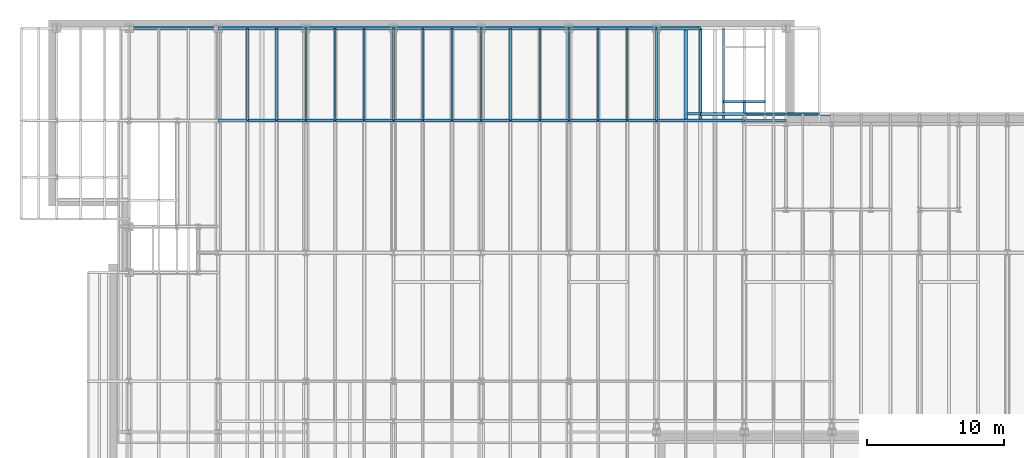
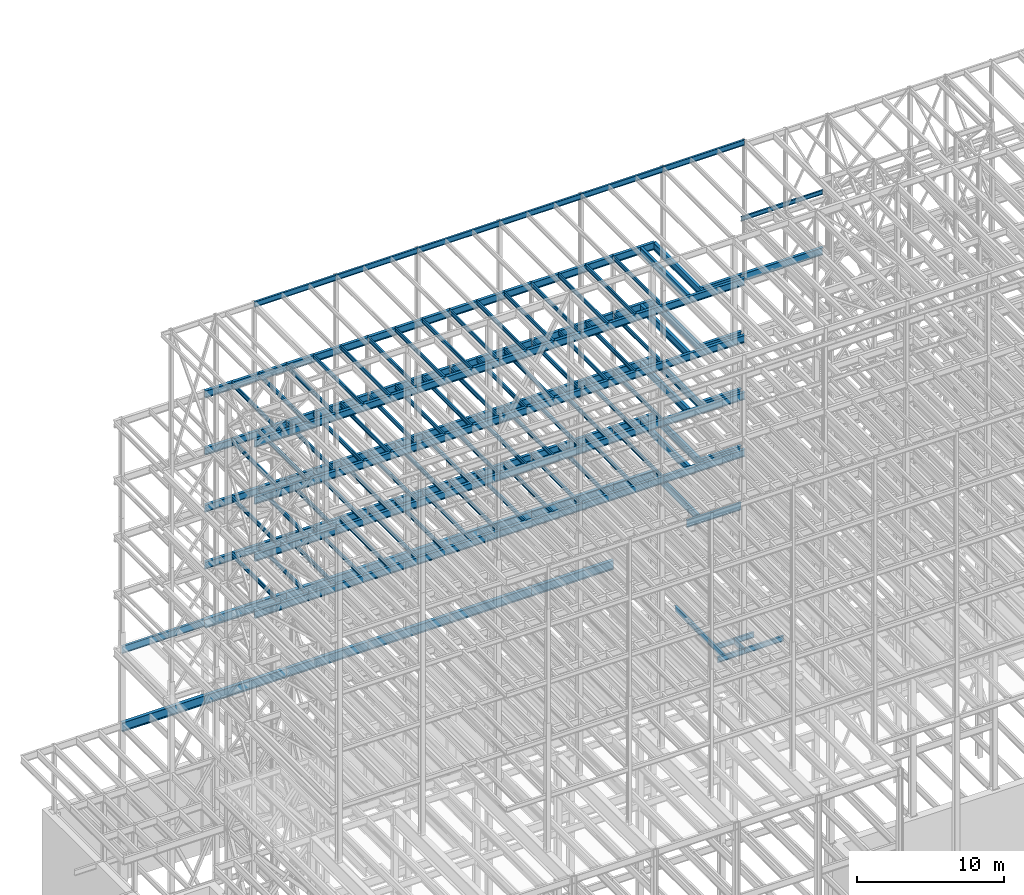
# One storey, part 137 of 150: 148 beams.
"""IFC2X3 building model written with IfcOpenShell, lengths in millimetres."""

from ifc_helpers import new_model, si_unit, frame, origin_with_axes, origin_2d_with_axis, place, context, subcontext, project, spatial, i_section, extrude, material, type_object, element, save


model = new_model("IFC2X3")

# Units and contexts
model_context = context("Model", 3, precision=1e-05, world=origin_with_axes())
body_context = subcontext(model_context, "Body", "Model", "MODEL_VIEW")
ifc_project = project(units=[si_unit("LENGTHUNIT", "METRE", prefix="MILLI"), si_unit("AREAUNIT", "SQUARE_METRE"), si_unit("VOLUMEUNIT", "CUBIC_METRE"), si_unit("MASSUNIT", "GRAM", prefix="KILO"), si_unit("TIMEUNIT", "SECOND"), si_unit("PLANEANGLEUNIT", "RADIAN"), si_unit("SOLIDANGLEUNIT", "STERADIAN"), si_unit("THERMODYNAMICTEMPERATUREUNIT", "DEGREE_CELSIUS"), si_unit("LUMINOUSINTENSITYUNIT", "LUMEN")], contexts=[model_context])

# Site, building, storey
site_placement = place(None, origin_with_axes())
site = spatial("IfcSite", under=ifc_project, at=site_placement, CompositionType="ELEMENT")
building_placement = place(site_placement, origin_with_axes())
building = spatial("IfcBuilding", under=site, at=building_placement, Name="Undefined", CompositionType="ELEMENT")
storey_placement = place(building_placement, origin_with_axes())
storey = spatial("IfcBuildingStorey", under=building, at=storey_placement, Name="Undefined", CompositionType="ELEMENT", Elevation=0.0)

# Beams
ifc_material = material(Name="STEEL/A992")
beam_type_1 = type_object("IfcBeamType", Name="W18X35", PredefinedType="NOTDEFINED")
for number, where, z_axis, x_axis, name in (
    (1, (43789.6, 32131.0, 65687.575), (0.0, 0.0, 1.0), (1.0, 0.0, 0.0), "BEAM"),
    (2, (37388.8, 32131.0, 65687.575), (0.0, 0.0, 1.0), (1.0, 0.0, 0.0), "BEAM"),
):
    element("IfcBeam", number, at=place(storey_placement, frame(where, z_axis=z_axis, x_axis=x_axis)), inside=storey, type_object=beam_type_1, material=ifc_material, Name=name, ObjectType="W18X35", context=body_context, shape_type="SweptSolid", body=[
        extrude(i_section(OverallWidth=152.4, OverallDepth=450.85, WebThickness=7.9375, FlangeThickness=10.795, FilletRadius=17.78, at=origin_2d_with_axis()), frame((6400.80000000001, 0.0, 0.0), z_axis=(-1.0, 0.0, 0.0), x_axis=(0.0, -1.0, 0.0)), (0.0, 0.0, 1.0), 6400.8),
    ])
beam_1_placement = place(storey_placement, frame((30988.0, 32131.0, 65687.575), z_axis=(0.0, 0.0, 1.0), x_axis=(1.0, 0.0, 0.0)))
element("IfcBeam", 3, at=beam_1_placement, inside=storey, type_object=beam_type_1, material=ifc_material, Name="BEAM", ObjectType="W18X35", context=body_context, shape_type="SweptSolid", body=[
    extrude(i_section(OverallWidth=152.4, OverallDepth=450.85, WebThickness=7.9375, FlangeThickness=10.795, FilletRadius=17.78, at=origin_2d_with_axis()), frame((6400.80000000001, 0.0, 0.0), z_axis=(-1.0, 0.0, 0.0), x_axis=(0.0, -1.0, 0.0)), (0.0, 0.0, 1.0), 6400.80000000001),
])
for number, where, z_axis, x_axis, name in (
    (4, (24587.2, 32131.0, 65687.575), (0.0, 0.0, 1.0), (1.0, 0.0, 0.0), "BEAM"),
    (5, (18186.4, 32131.0, 65687.575), (0.0, 0.0, 1.0), (1.0, 0.0, 0.0), "BEAM"),
    (6, (11785.6, 32131.0, 65687.575), (0.0, 0.0, 1.0), (1.0, 0.0, 0.0), "BEAM"),
):
    element("IfcBeam", number, at=place(storey_placement, frame(where, z_axis=z_axis, x_axis=x_axis)), inside=storey, type_object=beam_type_1, material=ifc_material, Name=name, ObjectType="W18X35", context=body_context, shape_type="SweptSolid", body=[
        extrude(i_section(OverallWidth=152.4, OverallDepth=450.85, WebThickness=7.9375, FlangeThickness=10.795, FilletRadius=17.78, at=origin_2d_with_axis()), frame((6400.80000000001, 0.0, 0.0), z_axis=(-1.0, 0.0, 0.0), x_axis=(0.0, -1.0, 0.0)), (0.0, 0.0, 1.0), 6400.8),
    ])
beam_2_placement = place(storey_placement, frame((50190.4, 32131.0, 23548.975), z_axis=(0.0, 0.0, 1.0), x_axis=(0.0, 1.0, 0.0)))
element("IfcBeam", 7, at=beam_2_placement, inside=storey, type_object=beam_type_1, material=ifc_material, Name="BEAM", ObjectType="W18X35", context=body_context, shape_type="SweptSolid", body=[
    extrude(i_section(OverallWidth=152.4, OverallDepth=450.85, WebThickness=7.9375, FlangeThickness=10.795, FilletRadius=17.78, at=origin_2d_with_axis()), frame((1371.6, 0.0, 0.0), z_axis=(-1.0, 0.0, 0.0), x_axis=(0.0, -1.0, 0.0)), (0.0, 0.0, 1.0), 1371.6),
])
beam_3_placement = place(storey_placement, frame((48666.4, 33502.6, 23548.975), z_axis=(0.0, 0.0, 1.0), x_axis=(1.0, 0.0, 0.0)))
element("IfcBeam", 8, at=beam_3_placement, inside=storey, type_object=beam_type_1, material=ifc_material, Name="BEAM", ObjectType="W18X35", context=body_context, shape_type="SweptSolid", body=[
    extrude(i_section(OverallWidth=152.4, OverallDepth=450.85, WebThickness=7.9375, FlangeThickness=10.795, FilletRadius=17.78, at=origin_2d_with_axis()), frame((3048.0, 0.0, 0.0), z_axis=(-1.0, 0.0, 0.0), x_axis=(0.0, -1.0, 0.0)), (0.0, 0.0, 1.0), 3048.0),
])
beam_4_placement = place(storey_placement, frame((48666.4, 32131.0, 23548.975), z_axis=(0.0, 0.0, 1.0), x_axis=(0.0, 1.0, 0.0)))
element("IfcBeam", 9, at=beam_4_placement, inside=storey, type_object=beam_type_1, material=ifc_material, Name="BEAM", ObjectType="W18X35", context=body_context, shape_type="SweptSolid", body=[
    extrude(i_section(OverallWidth=152.4, OverallDepth=450.85, WebThickness=7.9375, FlangeThickness=10.795, FilletRadius=17.78, at=origin_2d_with_axis()), frame((6731.0, 0.0, 0.0), z_axis=(-1.0, 0.0, 0.0), x_axis=(0.0, -1.0, 0.0)), (0.0, 0.0, 1.0), 6731.0),
])
beam_5_placement = place(storey_placement, frame((48056.8, 32131.0, 23548.975), z_axis=(0.0, 0.0, 1.0), x_axis=(1.0, 0.0, 0.0)))
element("IfcBeam", 10, at=beam_5_placement, inside=storey, type_object=beam_type_1, material=ifc_material, Name="BEAM", ObjectType="W18X35", context=body_context, shape_type="SweptSolid", body=[
    extrude(i_section(OverallWidth=152.4, OverallDepth=450.85, WebThickness=7.9375, FlangeThickness=10.795, FilletRadius=17.78, at=origin_2d_with_axis()), frame((2133.6, 0.0, 0.0), z_axis=(-1.0, 0.0, 0.0), x_axis=(0.0, -1.0, 0.0)), (0.0, 0.0, 1.0), 2133.60000000001),
])
beam_6_placement = place(storey_placement, frame((50190.4, 32131.0, 23548.975), z_axis=(0.0, 0.0, 1.0), x_axis=(1.0, 0.0, 0.0)))
element("IfcBeam", 11, at=beam_6_placement, inside=storey, type_object=beam_type_1, material=ifc_material, Name="BEAM", ObjectType="W18X35", context=body_context, shape_type="SweptSolid", body=[
    extrude(i_section(OverallWidth=152.4, OverallDepth=450.85, WebThickness=7.9375, FlangeThickness=10.795, FilletRadius=17.78, at=origin_2d_with_axis()), frame((3048.0, 0.0, 0.0), z_axis=(-1.0, 0.0, 0.0), x_axis=(0.0, -1.0, 0.0)), (0.0, 0.0, 1.0), 3048.0),
])
beam_type_2 = type_object("IfcBeamType", Name="W24X68", PredefinedType="NOTDEFINED")
for number, where, z_axis, x_axis, name in (
    (12, (37388.8, 32131.0, 54181.375), (0.0, 0.0, 1.0), (1.0, 0.0, 0.0), "BEAM"),
    (13, (30988.0, 32131.0, 54181.375), (0.0, 0.0, 1.0), (1.0, 0.0, 0.0), "BEAM"),
    (14, (24587.2, 32131.0, 54181.375), (0.0, 0.0, 1.0), (1.0, 0.0, 0.0), "BEAM"),
    (15, (18186.4, 32131.0, 54181.375), (0.0, 0.0, 1.0), (1.0, 0.0, 0.0), "BEAM"),
    (16, (11785.6, 32131.0, 54181.375), (0.0, 0.0, 1.0), (1.0, 0.0, 0.0), "BEAM"),
    (17, (37388.8, 38862.0, 54181.375), (0.0, 0.0, 1.0), (1.0, 0.0, 0.0), "BEAM"),
    (18, (30988.0, 38862.0, 54181.375), (0.0, 0.0, 1.0), (1.0, 0.0, 0.0), "BEAM"),
    (19, (24587.2, 38862.0, 54181.375), (0.0, 0.0, 1.0), (1.0, 0.0, 0.0), "BEAM"),
    (20, (18186.4, 38862.0, 54181.375), (0.0, 0.0, 1.0), (1.0, 0.0, 0.0), "BEAM"),
    (21, (11785.6, 38862.0, 54181.375), (0.0, 0.0, 1.0), (1.0, 0.0, 0.0), "BEAM"),
):
    element("IfcBeam", number, at=place(storey_placement, frame(where, z_axis=z_axis, x_axis=x_axis)), inside=storey, type_object=beam_type_2, material=ifc_material, Name=name, ObjectType="W24X68", context=body_context, shape_type="SweptSolid", body=[
        extrude(i_section(OverallWidth=227.838, OverallDepth=603.25, WebThickness=11.1125, FlangeThickness=14.859, FilletRadius=23.2409, at=origin_2d_with_axis()), frame((6400.80000000001, 0.0, 0.0), z_axis=(-1.0, 0.0, 0.0), x_axis=(0.0, -1.0, 0.0)), (0.0, 0.0, 1.0), 6400.8),
    ])
beam_7_placement = place(storey_placement, frame((45923.2, 32131.0, 54181.375), z_axis=(0.0, 0.0, 1.0), x_axis=(0.0, 1.0, 0.0)))
element("IfcBeam", 22, at=beam_7_placement, inside=storey, type_object=beam_type_2, material=ifc_material, Name="BEAM", ObjectType="W24X68", context=body_context, shape_type="SweptSolid", body=[
    extrude(i_section(OverallWidth=227.838, OverallDepth=603.25, WebThickness=11.1125, FlangeThickness=14.859, FilletRadius=23.2409, at=origin_2d_with_axis()), frame((6731.0, 0.0, 0.0), z_axis=(-1.0, 0.0, 0.0), x_axis=(0.0, -1.0, 0.0)), (0.0, 0.0, 1.0), 6731.0),
])
beam_8_placement = place(storey_placement, frame((43789.6, 32131.0, 54181.375), z_axis=(0.0, 0.0, 1.0), x_axis=(1.0, 0.0, 0.0)))
element("IfcBeam", 23, at=beam_8_placement, inside=storey, type_object=beam_type_2, material=ifc_material, Name="BEAM", ObjectType="W24X68", context=body_context, shape_type="SweptSolid", body=[
    extrude(i_section(OverallWidth=227.838, OverallDepth=603.25, WebThickness=11.1125, FlangeThickness=14.859, FilletRadius=23.2409, at=origin_2d_with_axis()), frame((6400.79935992001, 0.0, 0.0), z_axis=(-1.0, 0.0, 0.0), x_axis=(0.0, -1.0, 0.0)), (0.0, 0.0, 1.0), 6400.79935992001),
])
beam_9_placement = place(storey_placement, frame((43789.6, 38862.0, 54181.375), z_axis=(0.0, 0.0, 1.0), x_axis=(1.0, 0.0, 0.0)))
element("IfcBeam", 24, at=beam_9_placement, inside=storey, type_object=beam_type_2, material=ifc_material, Name="BEAM", ObjectType="W24X68", context=body_context, shape_type="SweptSolid", body=[
    extrude(i_section(OverallWidth=227.838, OverallDepth=603.25, WebThickness=11.1125, FlangeThickness=14.859, FilletRadius=23.2409, at=origin_2d_with_axis()), frame((3200.4, 0.0, 0.0), z_axis=(-1.0, 0.0, 0.0), x_axis=(0.0, -1.0, 0.0)), (0.0, 0.0, 1.0), 3200.4),
])
beam_10_placement = place(storey_placement, frame((46990.0, 32131.0, 54181.375), z_axis=(0.0, 0.0, 1.0), x_axis=(0.0, 1.0, 0.0)))
element("IfcBeam", 25, at=beam_10_placement, inside=storey, type_object=beam_type_2, material=ifc_material, Name="BEAM", ObjectType="W24X68", context=body_context, shape_type="SweptSolid", body=[
    extrude(i_section(OverallWidth=227.838, OverallDepth=603.25, WebThickness=11.1125, FlangeThickness=14.859, FilletRadius=23.2409, at=origin_2d_with_axis()), frame((6731.0, 0.0, 0.0), z_axis=(-1.0, 0.0, 0.0), x_axis=(0.0, -1.0, 0.0)), (0.0, 0.0, 1.0), 6731.0),
])
beam_11_placement = place(storey_placement, frame((46990.0, 32613.6, 54181.375), z_axis=(0.0, 0.0, 1.0), x_axis=(1.0, 0.0, 0.0)))
element("IfcBeam", 26, at=beam_11_placement, inside=storey, type_object=beam_type_2, material=ifc_material, Name="BEAM", ObjectType="W24X68", context=body_context, shape_type="SweptSolid", body=[
    extrude(i_section(OverallWidth=227.838, OverallDepth=603.25, WebThickness=11.1125, FlangeThickness=14.859, FilletRadius=23.2409, at=origin_2d_with_axis()), frame((3200.4, 0.0, 0.0), z_axis=(-1.0, 0.0, 0.0), x_axis=(0.0, -1.0, 0.0)), (0.0, 0.0, 1.0), 3200.4),
])
for number, where, z_axis, x_axis, name in (
    (27, (50190.4, 32613.6, 54181.375), (0.0, 0.0, 1.0), (1.0, 0.0, 0.0), "BEAM"),
    (28, (37388.8, 32131.0, 49456.975), (0.0, 0.0, 1.0), (1.0, 0.0, 0.0), "BEAM"),
    (29, (30988.0, 32131.0, 49456.975), (0.0, 0.0, 1.0), (1.0, 0.0, 0.0), "BEAM"),
    (30, (24587.2, 32131.0, 49456.975), (0.0, 0.0, 1.0), (1.0, 0.0, 0.0), "BEAM"),
    (31, (18186.4, 32131.0, 49456.975), (0.0, 0.0, 1.0), (1.0, 0.0, 0.0), "BEAM"),
    (32, (11785.6, 32131.0, 49456.975), (0.0, 0.0, 1.0), (1.0, 0.0, 0.0), "BEAM"),
    (33, (37388.8, 38862.0, 49456.975), (0.0, 0.0, 1.0), (1.0, 0.0, 0.0), "BEAM"),
    (34, (30988.0, 38862.0, 49456.975), (0.0, 0.0, 1.0), (1.0, 0.0, 0.0), "BEAM"),
    (35, (24587.2, 38862.0, 49456.975), (0.0, 0.0, 1.0), (1.0, 0.0, 0.0), "BEAM"),
    (36, (18186.4, 38862.0, 49456.975), (0.0, 0.0, 1.0), (1.0, 0.0, 0.0), "BEAM"),
    (37, (11785.6, 38862.0, 49456.975), (0.0, 0.0, 1.0), (1.0, 0.0, 0.0), "BEAM"),
):
    element("IfcBeam", number, at=place(storey_placement, frame(where, z_axis=z_axis, x_axis=x_axis)), inside=storey, type_object=beam_type_2, material=ifc_material, Name=name, ObjectType="W24X68", context=body_context, shape_type="SweptSolid", body=[
        extrude(i_section(OverallWidth=227.838, OverallDepth=603.25, WebThickness=11.1125, FlangeThickness=14.859, FilletRadius=23.2409, at=origin_2d_with_axis()), frame((6400.80000000001, 0.0, 0.0), z_axis=(-1.0, 0.0, 0.0), x_axis=(0.0, -1.0, 0.0)), (0.0, 0.0, 1.0), 6400.8),
    ])
beam_12_placement = place(storey_placement, frame((45923.2, 32131.0, 49456.975), z_axis=(0.0, 0.0, 1.0), x_axis=(0.0, 1.0, 0.0)))
element("IfcBeam", 38, at=beam_12_placement, inside=storey, type_object=beam_type_2, material=ifc_material, Name="BEAM", ObjectType="W24X68", context=body_context, shape_type="SweptSolid", body=[
    extrude(i_section(OverallWidth=227.838, OverallDepth=603.25, WebThickness=11.1125, FlangeThickness=14.859, FilletRadius=23.2409, at=origin_2d_with_axis()), frame((6731.0, 0.0, 0.0), z_axis=(-1.0, 0.0, 0.0), x_axis=(0.0, -1.0, 0.0)), (0.0, 0.0, 1.0), 6731.0),
])
beam_13_placement = place(storey_placement, frame((43789.6, 32131.0, 49456.975), z_axis=(0.0, 0.0, 1.0), x_axis=(1.0, 0.0, 0.0)))
element("IfcBeam", 39, at=beam_13_placement, inside=storey, type_object=beam_type_2, material=ifc_material, Name="BEAM", ObjectType="W24X68", context=body_context, shape_type="SweptSolid", body=[
    extrude(i_section(OverallWidth=227.838, OverallDepth=603.25, WebThickness=11.1125, FlangeThickness=14.859, FilletRadius=23.2409, at=origin_2d_with_axis()), frame((6400.79935992001, 0.0, 0.0), z_axis=(-1.0, 0.0, 0.0), x_axis=(0.0, -1.0, 0.0)), (0.0, 0.0, 1.0), 6400.79935992001),
])
beam_14_placement = place(storey_placement, frame((43789.6, 38862.0, 49456.975), z_axis=(0.0, 0.0, 1.0), x_axis=(1.0, 0.0, 0.0)))
element("IfcBeam", 40, at=beam_14_placement, inside=storey, type_object=beam_type_2, material=ifc_material, Name="BEAM", ObjectType="W24X68", context=body_context, shape_type="SweptSolid", body=[
    extrude(i_section(OverallWidth=227.838, OverallDepth=603.25, WebThickness=11.1125, FlangeThickness=14.859, FilletRadius=23.2409, at=origin_2d_with_axis()), frame((3200.4, 0.0, 0.0), z_axis=(-1.0, 0.0, 0.0), x_axis=(0.0, -1.0, 0.0)), (0.0, 0.0, 1.0), 3200.4),
])
beam_15_placement = place(storey_placement, frame((46990.0, 32131.0, 49456.975), z_axis=(0.0, 0.0, 1.0), x_axis=(0.0, 1.0, 0.0)))
element("IfcBeam", 41, at=beam_15_placement, inside=storey, type_object=beam_type_2, material=ifc_material, Name="BEAM", ObjectType="W24X68", context=body_context, shape_type="SweptSolid", body=[
    extrude(i_section(OverallWidth=227.838, OverallDepth=603.25, WebThickness=11.1125, FlangeThickness=14.859, FilletRadius=23.2409, at=origin_2d_with_axis()), frame((6731.0, 0.0, 0.0), z_axis=(-1.0, 0.0, 0.0), x_axis=(0.0, -1.0, 0.0)), (0.0, 0.0, 1.0), 6731.0),
])
beam_16_placement = place(storey_placement, frame((46990.0, 32613.6, 49456.975), z_axis=(0.0, 0.0, 1.0), x_axis=(1.0, 0.0, 0.0)))
element("IfcBeam", 42, at=beam_16_placement, inside=storey, type_object=beam_type_2, material=ifc_material, Name="BEAM", ObjectType="W24X68", context=body_context, shape_type="SweptSolid", body=[
    extrude(i_section(OverallWidth=227.838, OverallDepth=603.25, WebThickness=11.1125, FlangeThickness=14.859, FilletRadius=23.2409, at=origin_2d_with_axis()), frame((3200.4, 0.0, 0.0), z_axis=(-1.0, 0.0, 0.0), x_axis=(0.0, -1.0, 0.0)), (0.0, 0.0, 1.0), 3200.4),
])
for number, where, z_axis, x_axis, name in (
    (43, (37388.8, 32131.0, 44732.575), (0.0, 0.0, 1.0), (1.0, 0.0, 0.0), "BEAM"),
    (44, (30988.0, 32131.0, 44732.575), (0.0, 0.0, 1.0), (1.0, 0.0, 0.0), "BEAM"),
    (45, (24587.2, 32131.0, 44732.575), (0.0, 0.0, 1.0), (1.0, 0.0, 0.0), "BEAM"),
    (46, (18186.4, 32131.0, 44732.575), (0.0, 0.0, 1.0), (1.0, 0.0, 0.0), "BEAM"),
    (47, (11785.6, 32131.0, 44732.575), (0.0, 0.0, 1.0), (1.0, 0.0, 0.0), "BEAM"),
    (48, (37388.8, 38862.0, 44732.575), (0.0, 0.0, 1.0), (1.0, 0.0, 0.0), "BEAM"),
    (49, (30988.0, 38862.0, 44732.575), (0.0, 0.0, 1.0), (1.0, 0.0, 0.0), "BEAM"),
    (50, (24587.2, 38862.0, 44732.575), (0.0, 0.0, 1.0), (1.0, 0.0, 0.0), "BEAM"),
    (51, (18186.4, 38862.0, 44732.575), (0.0, 0.0, 1.0), (1.0, 0.0, 0.0), "BEAM"),
    (52, (11785.6, 38862.0, 44732.575), (0.0, 0.0, 1.0), (1.0, 0.0, 0.0), "BEAM"),
):
    element("IfcBeam", number, at=place(storey_placement, frame(where, z_axis=z_axis, x_axis=x_axis)), inside=storey, type_object=beam_type_2, material=ifc_material, Name=name, ObjectType="W24X68", context=body_context, shape_type="SweptSolid", body=[
        extrude(i_section(OverallWidth=227.838, OverallDepth=603.25, WebThickness=11.1125, FlangeThickness=14.859, FilletRadius=23.2409, at=origin_2d_with_axis()), frame((6400.80000000001, 0.0, 0.0), z_axis=(-1.0, 0.0, 0.0), x_axis=(0.0, -1.0, 0.0)), (0.0, 0.0, 1.0), 6400.8),
    ])
beam_17_placement = place(storey_placement, frame((45923.2, 32131.0, 44732.575), z_axis=(0.0, 0.0, 1.0), x_axis=(0.0, 1.0, 0.0)))
element("IfcBeam", 53, at=beam_17_placement, inside=storey, type_object=beam_type_2, material=ifc_material, Name="BEAM", ObjectType="W24X68", context=body_context, shape_type="SweptSolid", body=[
    extrude(i_section(OverallWidth=227.838, OverallDepth=603.25, WebThickness=11.1125, FlangeThickness=14.859, FilletRadius=23.2409, at=origin_2d_with_axis()), frame((6731.0, 0.0, 0.0), z_axis=(-1.0, 0.0, 0.0), x_axis=(0.0, -1.0, 0.0)), (0.0, 0.0, 1.0), 6731.0),
])
beam_18_placement = place(storey_placement, frame((43789.6, 32131.0, 44732.575), z_axis=(0.0, 0.0, 1.0), x_axis=(1.0, 0.0, 0.0)))
element("IfcBeam", 54, at=beam_18_placement, inside=storey, type_object=beam_type_2, material=ifc_material, Name="BEAM", ObjectType="W24X68", context=body_context, shape_type="SweptSolid", body=[
    extrude(i_section(OverallWidth=227.838, OverallDepth=603.25, WebThickness=11.1125, FlangeThickness=14.859, FilletRadius=23.2409, at=origin_2d_with_axis()), frame((6400.79935992001, 0.0, 0.0), z_axis=(-1.0, 0.0, 0.0), x_axis=(0.0, -1.0, 0.0)), (0.0, 0.0, 1.0), 6400.79935992001),
])
beam_19_placement = place(storey_placement, frame((43789.6, 38862.0, 44732.575), z_axis=(0.0, 0.0, 1.0), x_axis=(1.0, 0.0, 0.0)))
element("IfcBeam", 55, at=beam_19_placement, inside=storey, type_object=beam_type_2, material=ifc_material, Name="BEAM", ObjectType="W24X68", context=body_context, shape_type="SweptSolid", body=[
    extrude(i_section(OverallWidth=227.838, OverallDepth=603.25, WebThickness=11.1125, FlangeThickness=14.859, FilletRadius=23.2409, at=origin_2d_with_axis()), frame((3200.4, 0.0, 0.0), z_axis=(-1.0, 0.0, 0.0), x_axis=(0.0, -1.0, 0.0)), (0.0, 0.0, 1.0), 3200.4),
])
beam_20_placement = place(storey_placement, frame((46990.0, 32131.0, 44732.575), z_axis=(0.0, 0.0, 1.0), x_axis=(0.0, 1.0, 0.0)))
element("IfcBeam", 56, at=beam_20_placement, inside=storey, type_object=beam_type_2, material=ifc_material, Name="BEAM", ObjectType="W24X68", context=body_context, shape_type="SweptSolid", body=[
    extrude(i_section(OverallWidth=227.838, OverallDepth=603.25, WebThickness=11.1125, FlangeThickness=14.859, FilletRadius=23.2409, at=origin_2d_with_axis()), frame((6731.0, 0.0, 0.0), z_axis=(-1.0, 0.0, 0.0), x_axis=(0.0, -1.0, 0.0)), (0.0, 0.0, 1.0), 6731.0),
])
beam_21_placement = place(storey_placement, frame((46990.0, 32613.6, 44732.575), z_axis=(0.0, 0.0, 1.0), x_axis=(1.0, 0.0, 0.0)))
element("IfcBeam", 57, at=beam_21_placement, inside=storey, type_object=beam_type_2, material=ifc_material, Name="BEAM", ObjectType="W24X68", context=body_context, shape_type="SweptSolid", body=[
    extrude(i_section(OverallWidth=227.838, OverallDepth=603.25, WebThickness=11.1125, FlangeThickness=14.859, FilletRadius=23.2409, at=origin_2d_with_axis()), frame((3200.4, 0.0, 0.0), z_axis=(-1.0, 0.0, 0.0), x_axis=(0.0, -1.0, 0.0)), (0.0, 0.0, 1.0), 3200.4),
])
for number, where, z_axis, x_axis, name in (
    (58, (37388.8, 32131.0, 40008.175), (0.0, 0.0, 1.0), (1.0, 0.0, 0.0), "BEAM"),
    (59, (30988.0, 32131.0, 40008.175), (0.0, 0.0, 1.0), (1.0, 0.0, 0.0), "BEAM"),
    (60, (24587.2, 32131.0, 40008.175), (0.0, 0.0, 1.0), (1.0, 0.0, 0.0), "BEAM"),
    (61, (18186.4, 32131.0, 40008.175), (0.0, 0.0, 1.0), (1.0, 0.0, 0.0), "BEAM"),
    (62, (11785.6, 32131.0, 40008.175), (0.0, 0.0, 1.0), (1.0, 0.0, 0.0), "BEAM"),
    (63, (37388.8, 38862.0, 40008.175), (0.0, 0.0, 1.0), (1.0, 0.0, 0.0), "BEAM"),
    (64, (30988.0, 38862.0, 40008.175), (0.0, 0.0, 1.0), (1.0, 0.0, 0.0), "BEAM"),
    (65, (24587.2, 38862.0, 40008.175), (0.0, 0.0, 1.0), (1.0, 0.0, 0.0), "BEAM"),
    (66, (18186.4, 38862.0, 40008.175), (0.0, 0.0, 1.0), (1.0, 0.0, 0.0), "BEAM"),
    (67, (11785.6, 38862.0, 40008.175), (0.0, 0.0, 1.0), (1.0, 0.0, 0.0), "BEAM"),
):
    element("IfcBeam", number, at=place(storey_placement, frame(where, z_axis=z_axis, x_axis=x_axis)), inside=storey, type_object=beam_type_2, material=ifc_material, Name=name, ObjectType="W24X68", context=body_context, shape_type="SweptSolid", body=[
        extrude(i_section(OverallWidth=227.838, OverallDepth=603.25, WebThickness=11.1125, FlangeThickness=14.859, FilletRadius=23.2409, at=origin_2d_with_axis()), frame((6400.80000000001, 0.0, 0.0), z_axis=(-1.0, 0.0, 0.0), x_axis=(0.0, -1.0, 0.0)), (0.0, 0.0, 1.0), 6400.8),
    ])
beam_22_placement = place(storey_placement, frame((45923.2, 32131.0, 40008.175), z_axis=(0.0, 0.0, 1.0), x_axis=(0.0, 1.0, 0.0)))
element("IfcBeam", 68, at=beam_22_placement, inside=storey, type_object=beam_type_2, material=ifc_material, Name="BEAM", ObjectType="W24X68", context=body_context, shape_type="SweptSolid", body=[
    extrude(i_section(OverallWidth=227.838, OverallDepth=603.25, WebThickness=11.1125, FlangeThickness=14.859, FilletRadius=23.2409, at=origin_2d_with_axis()), frame((6731.0, 0.0, 0.0), z_axis=(-1.0, 0.0, 0.0), x_axis=(0.0, -1.0, 0.0)), (0.0, 0.0, 1.0), 6731.0),
])
beam_23_placement = place(storey_placement, frame((43789.6, 32131.0, 40008.175), z_axis=(0.0, 0.0, 1.0), x_axis=(1.0, 0.0, 0.0)))
element("IfcBeam", 69, at=beam_23_placement, inside=storey, type_object=beam_type_2, material=ifc_material, Name="BEAM", ObjectType="W24X68", context=body_context, shape_type="SweptSolid", body=[
    extrude(i_section(OverallWidth=227.838, OverallDepth=603.25, WebThickness=11.1125, FlangeThickness=14.859, FilletRadius=23.2409, at=origin_2d_with_axis()), frame((6400.80000000001, 0.0, 0.0), z_axis=(-1.0, 0.0, 0.0), x_axis=(0.0, -1.0, 0.0)), (0.0, 0.0, 1.0), 6400.80000000001),
])
beam_24_placement = place(storey_placement, frame((43789.6, 38862.0, 40008.175), z_axis=(0.0, 0.0, 1.0), x_axis=(1.0, 0.0, 0.0)))
element("IfcBeam", 70, at=beam_24_placement, inside=storey, type_object=beam_type_2, material=ifc_material, Name="BEAM", ObjectType="W24X68", context=body_context, shape_type="SweptSolid", body=[
    extrude(i_section(OverallWidth=227.838, OverallDepth=603.25, WebThickness=11.1125, FlangeThickness=14.859, FilletRadius=23.2409, at=origin_2d_with_axis()), frame((3200.4, 0.0, 0.0), z_axis=(-1.0, 0.0, 0.0), x_axis=(0.0, -1.0, 0.0)), (0.0, 0.0, 1.0), 3200.4),
])
beam_25_placement = place(storey_placement, frame((46990.0, 32131.0, 40008.175), z_axis=(0.0, 0.0, 1.0), x_axis=(0.0, 1.0, 0.0)))
element("IfcBeam", 71, at=beam_25_placement, inside=storey, type_object=beam_type_2, material=ifc_material, Name="BEAM", ObjectType="W24X68", context=body_context, shape_type="SweptSolid", body=[
    extrude(i_section(OverallWidth=227.838, OverallDepth=603.25, WebThickness=11.1125, FlangeThickness=14.859, FilletRadius=23.2409, at=origin_2d_with_axis()), frame((6731.0, 0.0, 0.0), z_axis=(-1.0, 0.0, 0.0), x_axis=(0.0, -1.0, 0.0)), (0.0, 0.0, 1.0), 6731.0),
])
beam_26_placement = place(storey_placement, frame((46990.0, 32613.6, 40008.175), z_axis=(0.0, 0.0, 1.0), x_axis=(1.0, 0.0, 0.0)))
element("IfcBeam", 72, at=beam_26_placement, inside=storey, type_object=beam_type_2, material=ifc_material, Name="BEAM", ObjectType="W24X68", context=body_context, shape_type="SweptSolid", body=[
    extrude(i_section(OverallWidth=227.838, OverallDepth=603.25, WebThickness=11.1125, FlangeThickness=14.859, FilletRadius=23.2409, at=origin_2d_with_axis()), frame((3200.4, 0.0, 0.0), z_axis=(-1.0, 0.0, 0.0), x_axis=(0.0, -1.0, 0.0)), (0.0, 0.0, 1.0), 3200.4),
])
beam_type_3 = type_object("IfcBeamType", Name="W14X22", PredefinedType="NOTDEFINED")
beam_27_placement = place(storey_placement, frame((50190.4, 32613.6, 59032.775), z_axis=(0.0, 0.0, 1.0), x_axis=(1.0, 0.0, 0.0)))
element("IfcBeam", 73, at=beam_27_placement, inside=storey, type_object=beam_type_3, material=ifc_material, Name="BEAM", ObjectType="W14X22", context=body_context, shape_type="SweptSolid", body=[
    extrude(i_section(OverallWidth=127.0, OverallDepth=349.25, WebThickness=6.3499, FlangeThickness=8.509, FilletRadius=18.4785, at=origin_2d_with_axis()), frame((6400.80000000001, 0.0, 0.0), z_axis=(-1.0, 0.0, 0.0), x_axis=(0.0, -1.0, 0.0)), (0.0, 0.0, 1.0), 6400.8),
])
for number, where, z_axis, x_axis, name in (
    (74, (43789.6, 32131.0, 54308.375), (0.0, 0.0, 1.0), (0.0, 1.0, 0.0), "BEAM"),
    (75, (37388.8, 32131.0, 54308.375), (0.0, 0.0, 1.0), (0.0, 1.0, 0.0), "BEAM"),
    (76, (41656.0, 32131.0, 54308.375), (0.0, 0.0, 1.0), (0.0, 1.0, 0.0), "BEAM"),
    (77, (39522.4, 32131.0, 54308.375), (0.0, 0.0, 1.0), (0.0, 1.0, 0.0), "BEAM"),
    (78, (30988.0, 32131.0, 54308.375), (0.0, 0.0, 1.0), (0.0, 1.0, 0.0), "BEAM"),
    (79, (35255.2, 32131.0, 54308.375), (0.0, 0.0, 1.0), (0.0, 1.0, 0.0), "BEAM"),
    (80, (33121.6, 32131.0, 54308.375), (0.0, 0.0, 1.0), (0.0, 1.0, 0.0), "BEAM"),
    (81, (24587.2, 32131.0, 54308.375), (0.0, 0.0, 1.0), (0.0, 1.0, 0.0), "BEAM"),
    (82, (28854.4, 32131.0, 54308.375), (0.0, 0.0, 1.0), (0.0, 1.0, 0.0), "BEAM"),
    (83, (26720.8, 32131.0, 54308.375), (0.0, 0.0, 1.0), (0.0, 1.0, 0.0), "BEAM"),
    (84, (18186.4, 32131.0, 54308.375), (0.0, 0.0, 1.0), (0.0, 1.0, 0.0), "BEAM"),
    (85, (22453.6, 32131.0, 54308.375), (0.0, 0.0, 1.0), (0.0, 1.0, 0.0), "BEAM"),
    (86, (20320.0, 32131.0, 54308.375), (0.0, 0.0, 1.0), (0.0, 1.0, 0.0), "BEAM"),
    (87, (16052.8, 32131.0, 54308.375), (0.0, 0.0, 1.0), (0.0, 1.0, 0.0), "BEAM"),
    (88, (13919.2, 32131.0, 54308.375), (0.0, 0.0, 1.0), (0.0, 1.0, 0.0), "BEAM"),
    (89, (43789.6, 32131.0, 49583.975), (0.0, 0.0, 1.0), (0.0, 1.0, 0.0), "BEAM"),
    (90, (37388.8, 32131.0, 49583.975), (0.0, 0.0, 1.0), (0.0, 1.0, 0.0), "BEAM"),
    (91, (41656.0, 32131.0, 49583.975), (0.0, 0.0, 1.0), (0.0, 1.0, 0.0), "BEAM"),
    (92, (39522.4, 32131.0, 49583.975), (0.0, 0.0, 1.0), (0.0, 1.0, 0.0), "BEAM"),
    (93, (30988.0, 32131.0, 49583.975), (0.0, 0.0, 1.0), (0.0, 1.0, 0.0), "BEAM"),
    (94, (35255.2, 32131.0, 49583.975), (0.0, 0.0, 1.0), (0.0, 1.0, 0.0), "BEAM"),
    (95, (33121.6, 32131.0, 49583.975), (0.0, 0.0, 1.0), (0.0, 1.0, 0.0), "BEAM"),
    (96, (24587.2, 32131.0, 49583.975), (0.0, 0.0, 1.0), (0.0, 1.0, 0.0), "BEAM"),
    (97, (28854.4, 32131.0, 49583.975), (0.0, 0.0, 1.0), (0.0, 1.0, 0.0), "BEAM"),
    (98, (26720.8, 32131.0, 49583.975), (0.0, 0.0, 1.0), (0.0, 1.0, 0.0), "BEAM"),
    (99, (18186.4, 32131.0, 49583.975), (0.0, 0.0, 1.0), (0.0, 1.0, 0.0), "BEAM"),
    (100, (22453.6, 32131.0, 49583.975), (0.0, 0.0, 1.0), (0.0, 1.0, 0.0), "BEAM"),
    (101, (20320.0, 32131.0, 49583.975), (0.0, 0.0, 1.0), (0.0, 1.0, 0.0), "BEAM"),
    (102, (16052.8, 32131.0, 49583.975), (0.0, 0.0, 1.0), (0.0, 1.0, 0.0), "BEAM"),
    (103, (13919.2, 32131.0, 49583.975), (0.0, 0.0, 1.0), (0.0, 1.0, 0.0), "BEAM"),
    (104, (43789.6, 32131.0, 44859.575), (0.0, 0.0, 1.0), (0.0, 1.0, 0.0), "BEAM"),
    (105, (37388.8, 32131.0, 44859.575), (0.0, 0.0, 1.0), (0.0, 1.0, 0.0), "BEAM"),
    (106, (41656.0, 32131.0, 44859.575), (0.0, 0.0, 1.0), (0.0, 1.0, 0.0), "BEAM"),
    (107, (39522.4, 32131.0, 44859.575), (0.0, 0.0, 1.0), (0.0, 1.0, 0.0), "BEAM"),
    (108, (30988.0, 32131.0, 44859.575), (0.0, 0.0, 1.0), (0.0, 1.0, 0.0), "BEAM"),
    (109, (35255.2, 32131.0, 44859.575), (0.0, 0.0, 1.0), (0.0, 1.0, 0.0), "BEAM"),
    (110, (33121.6, 32131.0, 44859.575), (0.0, 0.0, 1.0), (0.0, 1.0, 0.0), "BEAM"),
    (111, (24587.2, 32131.0, 44859.575), (0.0, 0.0, 1.0), (0.0, 1.0, 0.0), "BEAM"),
    (112, (28854.4, 32131.0, 44859.575), (0.0, 0.0, 1.0), (0.0, 1.0, 0.0), "BEAM"),
    (113, (26720.8, 32131.0, 44859.575), (0.0, 0.0, 1.0), (0.0, 1.0, 0.0), "BEAM"),
    (114, (18186.4, 32131.0, 44859.575), (0.0, 0.0, 1.0), (0.0, 1.0, 0.0), "BEAM"),
    (115, (22453.6, 32131.0, 44859.575), (0.0, 0.0, 1.0), (0.0, 1.0, 0.0), "BEAM"),
    (116, (20320.0, 32131.0, 44859.575), (0.0, 0.0, 1.0), (0.0, 1.0, 0.0), "BEAM"),
    (117, (16052.8, 32131.0, 44859.575), (0.0, 0.0, 1.0), (0.0, 1.0, 0.0), "BEAM"),
    (118, (13919.2, 32131.0, 44859.575), (0.0, 0.0, 1.0), (0.0, 1.0, 0.0), "BEAM"),
    (119, (43789.6, 32131.0, 40135.175), (0.0, 0.0, 1.0), (0.0, 1.0, 0.0), "BEAM"),
    (120, (37388.8, 32131.0, 40135.175), (0.0, 0.0, 1.0), (0.0, 1.0, 0.0), "BEAM"),
    (121, (41656.0, 32131.0, 40135.175), (0.0, 0.0, 1.0), (0.0, 1.0, 0.0), "BEAM"),
    (122, (39522.4, 32131.0, 40135.175), (0.0, 0.0, 1.0), (0.0, 1.0, 0.0), "BEAM"),
    (123, (30988.0, 32131.0, 40135.175), (0.0, 0.0, 1.0), (0.0, 1.0, 0.0), "BEAM"),
    (124, (35255.2, 32131.0, 40135.175), (0.0, 0.0, 1.0), (0.0, 1.0, 0.0), "BEAM"),
    (125, (33121.6, 32131.0, 40135.175), (0.0, 0.0, 1.0), (0.0, 1.0, 0.0), "BEAM"),
    (126, (24587.2, 32131.0, 40135.175), (0.0, 0.0, 1.0), (0.0, 1.0, 0.0), "BEAM"),
    (127, (28854.4, 32131.0, 40135.175), (0.0, 0.0, 1.0), (0.0, 1.0, 0.0), "BEAM"),
    (128, (26720.8, 32131.0, 40135.175), (0.0, 0.0, 1.0), (0.0, 1.0, 0.0), "BEAM"),
    (129, (18186.4, 32131.0, 40135.175), (0.0, 0.0, 1.0), (0.0, 1.0, 0.0), "BEAM"),
    (130, (22453.6, 32131.0, 40135.175), (0.0, 0.0, 1.0), (0.0, 1.0, 0.0), "BEAM"),
    (131, (20320.0, 32131.0, 40135.175), (0.0, 0.0, 1.0), (0.0, 1.0, 0.0), "BEAM"),
    (132, (16052.8, 32131.0, 40135.175), (0.0, 0.0, 1.0), (0.0, 1.0, 0.0), "BEAM"),
    (133, (13919.2, 32131.0, 40135.175), (0.0, 0.0, 1.0), (0.0, 1.0, 0.0), "BEAM"),
):
    element("IfcBeam", number, at=place(storey_placement, frame(where, z_axis=z_axis, x_axis=x_axis)), inside=storey, type_object=beam_type_3, material=ifc_material, Name=name, ObjectType="W14X22", context=body_context, shape_type="SweptSolid", body=[
        extrude(i_section(OverallWidth=127.0, OverallDepth=349.25, WebThickness=6.3499, FlangeThickness=8.509, FilletRadius=18.4785, at=origin_2d_with_axis()), frame((6731.0, 0.0, 0.0), z_axis=(-1.0, 0.0, 0.0), x_axis=(0.0, -1.0, 0.0)), (0.0, 0.0, 1.0), 6731.0),
    ])
beam_type_4 = type_object("IfcBeamType", Name="W24X62", PredefinedType="NOTDEFINED")
beam_28_placement = place(storey_placement, frame((5283.2, 38862.0, 35283.775), z_axis=(0.0, 0.0, 1.0), x_axis=(1.0, 0.0, 0.0)))
element("IfcBeam", 134, at=beam_28_placement, inside=storey, type_object=beam_type_4, material=ifc_material, Name="BEAM", ObjectType="W24X62", context=body_context, shape_type="SweptSolid", body=[
    extrude(i_section(OverallWidth=177.8, OverallDepth=603.25, WebThickness=11.1125, FlangeThickness=14.986, FilletRadius=23.114, at=origin_2d_with_axis()), frame((6502.4, 0.0, 0.0), z_axis=(-1.0, 0.0, 0.0), x_axis=(0.0, -1.0, 0.0)), (0.0, 0.0, 1.0), 6502.4),
])
beam_29_placement = place(storey_placement, frame((46990.0, 32613.6, 35283.775), z_axis=(0.0, 0.0, 1.0), x_axis=(0.0, 1.0, 0.0)))
element("IfcBeam", 135, at=beam_29_placement, inside=storey, type_object=beam_type_4, material=ifc_material, Name="BEAM", ObjectType="W24X62", context=body_context, shape_type="SweptSolid", body=[
    extrude(i_section(OverallWidth=177.8, OverallDepth=603.25, WebThickness=11.1125, FlangeThickness=14.986, FilletRadius=23.114, at=origin_2d_with_axis()), frame((6248.40000000001, 0.0, 0.0), z_axis=(-1.0, 0.0, 0.0), x_axis=(0.0, -1.0, 0.0)), (0.0, 0.0, 1.0), 6248.4),
])
beam_30_placement = place(storey_placement, frame((45923.2, 32613.6, 35283.775), z_axis=(0.0, 0.0, 1.0), x_axis=(1.0, 0.0, 0.0)))
element("IfcBeam", 136, at=beam_30_placement, inside=storey, type_object=beam_type_4, material=ifc_material, Name="BEAM", ObjectType="W24X62", context=body_context, shape_type="SweptSolid", body=[
    extrude(i_section(OverallWidth=177.8, OverallDepth=603.25, WebThickness=11.1125, FlangeThickness=14.986, FilletRadius=23.114, at=origin_2d_with_axis()), frame((4267.2, 0.0, 0.0), z_axis=(-1.0, 0.0, 0.0), x_axis=(0.0, -1.0, 0.0)), (0.0, 0.0, 1.0), 4267.2),
])
beam_type_5 = type_object("IfcBeamType", Name="W30X90", PredefinedType="NOTDEFINED")
for number, where, z_axis, x_axis, name in (
    (137, (30988.0, 38862.0, 35210.75), (0.0, 0.0, 1.0), (1.0, 0.0, 0.0), "BEAM"),
    (138, (24587.2, 38862.0, 35210.75), (0.0, 0.0, 1.0), (1.0, 0.0, 0.0), "BEAM"),
    (139, (18186.4, 38862.0, 35210.75), (0.0, 0.0, 1.0), (1.0, 0.0, 0.0), "BEAM"),
    (140, (11785.6, 38862.0, 35210.75), (0.0, 0.0, 1.0), (1.0, 0.0, 0.0), "BEAM"),
    (141, (37388.8, 38862.0, 35210.75), (0.0, 0.0, 1.0), (1.0, 0.0, 0.0), "BEAM"),
):
    element("IfcBeam", number, at=place(storey_placement, frame(where, z_axis=z_axis, x_axis=x_axis)), inside=storey, type_object=beam_type_5, material=ifc_material, Name=name, ObjectType="W30X90", context=body_context, shape_type="SweptSolid", body=[
        extrude(i_section(OverallWidth=264.16, OverallDepth=749.3, WebThickness=12.6999, FlangeThickness=15.494, FilletRadius=22.606, at=origin_2d_with_axis()), frame((6400.80000000001, 0.0, 0.0), z_axis=(-1.0, 0.0, 0.0), x_axis=(0.0, -1.0, 0.0)), (0.0, 0.0, 1.0), 6400.8),
    ])
beam_31_placement = place(storey_placement, frame((43789.6, 38862.0, 35210.75), z_axis=(0.0, 0.0, 1.0), x_axis=(1.0, 0.0, 0.0)))
element("IfcBeam", 142, at=beam_31_placement, inside=storey, type_object=beam_type_5, material=ifc_material, Name="BEAM", ObjectType="W30X90", context=body_context, shape_type="SweptSolid", body=[
    extrude(i_section(OverallWidth=264.16, OverallDepth=749.3, WebThickness=12.6999, FlangeThickness=15.494, FilletRadius=22.606, at=origin_2d_with_axis()), frame((3200.4, 0.0, 0.0), z_axis=(-1.0, 0.0, 0.0), x_axis=(0.0, -1.0, 0.0)), (0.0, 0.0, 1.0), 3200.4),
])
for number, where, z_axis, x_axis, name in (
    (143, (37388.8, 38862.0, 28911.55), (0.0, 0.0, 1.0), (1.0, 0.0, 0.0), "BEAM"),
    (144, (30988.0, 38862.0, 28911.55), (0.0, 0.0, 1.0), (1.0, 0.0, 0.0), "BEAM"),
    (145, (24587.2, 38862.0, 28911.55), (0.0, 0.0, 1.0), (1.0, 0.0, 0.0), "BEAM"),
    (146, (18186.4, 38862.0, 28911.55), (0.0, 0.0, 1.0), (1.0, 0.0, 0.0), "BEAM"),
    (147, (11785.6, 38862.0, 28911.55), (0.0, 0.0, 1.0), (1.0, 0.0, 0.0), "BEAM"),
):
    element("IfcBeam", number, at=place(storey_placement, frame(where, z_axis=z_axis, x_axis=x_axis)), inside=storey, type_object=beam_type_5, material=ifc_material, Name=name, ObjectType="W30X90", context=body_context, shape_type="SweptSolid", body=[
        extrude(i_section(OverallWidth=264.16, OverallDepth=749.3, WebThickness=12.6999, FlangeThickness=15.494, FilletRadius=22.606, at=origin_2d_with_axis()), frame((6400.80000000001, 0.0, 0.0), z_axis=(-1.0, 0.0, 0.0), x_axis=(0.0, -1.0, 0.0)), (0.0, 0.0, 1.0), 6400.8),
    ])
beam_32_placement = place(storey_placement, frame((5283.2, 38862.0, 28911.55), z_axis=(0.0, 0.0, 1.0), x_axis=(1.0, 0.0, 0.0)))
element("IfcBeam", 148, at=beam_32_placement, inside=storey, type_object=beam_type_5, material=ifc_material, Name="BEAM", ObjectType="W30X90", context=body_context, shape_type="SweptSolid", body=[
    extrude(i_section(OverallWidth=264.16, OverallDepth=749.3, WebThickness=12.6999, FlangeThickness=15.494, FilletRadius=22.606, at=origin_2d_with_axis()), frame((6502.4, 0.0, 0.0), z_axis=(-1.0, 0.0, 0.0), x_axis=(0.0, -1.0, 0.0)), (0.0, 0.0, 1.0), 6502.4),
])

save(model, "model.ifc")
